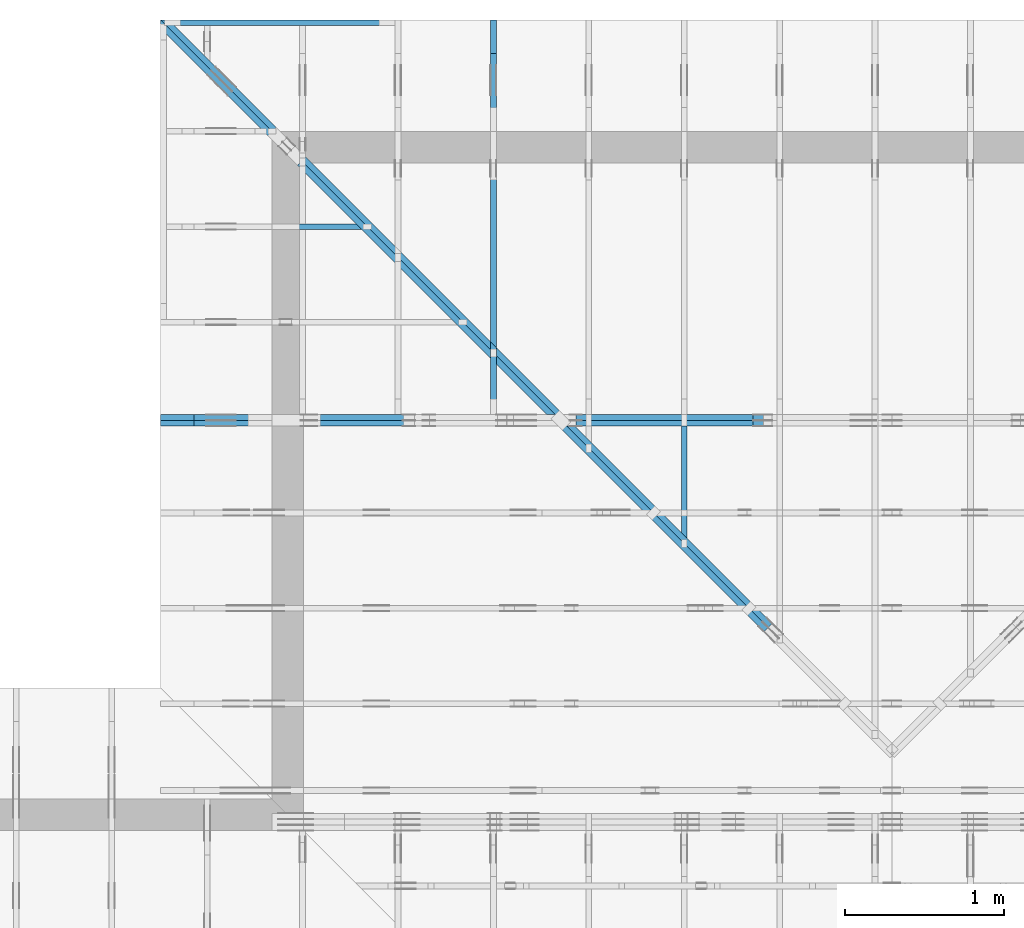
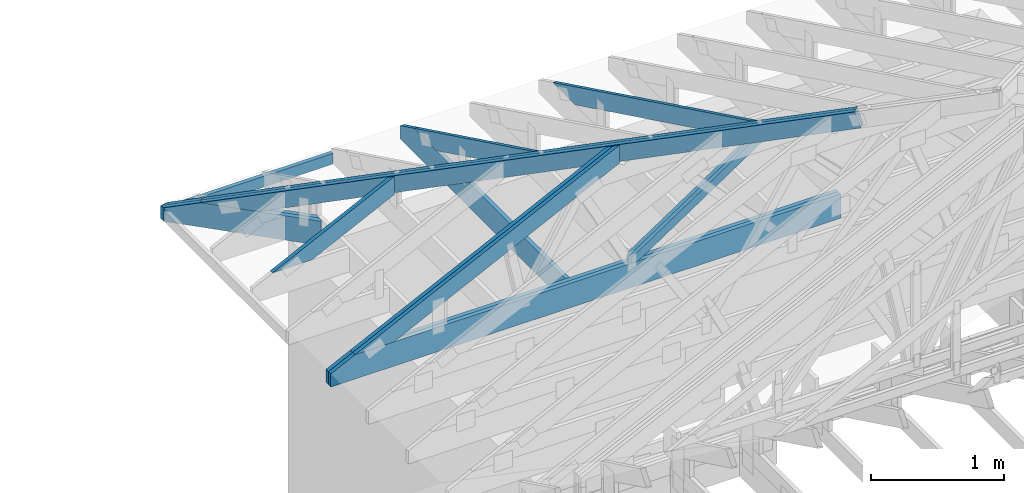
# One storey, part 26 of 159: 15 members, 6 elements without a shape of their own.
"""IFC2X3 building model written with IfcOpenShell, lengths in millimetres."""

from ifc_helpers import new_model, si_unit, frame, origin, origin_with_axes, origin_2d, place, context, project, spatial, faceted_brep, element, aggregate, save


model = new_model("IFC2X3")

# Units and contexts
model_context = context("Model", 3, precision=1e-05, world=origin())
plan_context = context("Plan", 2, precision=1e-05, world=origin_2d())
ifc_project = project(units=[si_unit("LENGTHUNIT", "METRE", prefix="MILLI"), si_unit("AREAUNIT", "SQUARE_METRE"), si_unit("VOLUMEUNIT", "CUBIC_METRE"), si_unit("SOLIDANGLEUNIT", "STERADIAN"), si_unit("PLANEANGLEUNIT", "RADIAN"), si_unit("MASSUNIT", "GRAM"), si_unit("TIMEUNIT", "SECOND"), si_unit("THERMODYNAMICTEMPERATUREUNIT", "DEGREE_CELSIUS"), si_unit("LUMINOUSINTENSITYUNIT", "LUMEN")], contexts=[model_context, plan_context])

# Site, building, storey
site_placement = place(None, origin_with_axes())
site = spatial("IfcSite", under=ifc_project, at=site_placement, CompositionType="ELEMENT")
building_placement = place(site_placement, origin_with_axes())
building = spatial("IfcBuilding", under=site, at=building_placement, Name="Plan 1", CompositionType="ELEMENT")
storey_placement = place(building_placement, origin_with_axes())
storey = spatial("IfcBuildingStorey", under=building, at=storey_placement, Name="Etasje 1", CompositionType="ELEMENT", Elevation=0.0)

# Assembly, members
assembly_1_placement = place(storey_placement, frame((19200.01266310149, 11417.999978540158, 0.0), z_axis=(1.2246063538223773e-16, 1.0, 6.123031769111886e-17), x_axis=(-1.0, 1.2246063538223773e-16, 0.0)))
assembly_1 = element("IfcElementAssembly", 1, at=assembly_1_placement, inside=storey, Name="V9 (1)", AssemblyPlace="FACTORY", PredefinedType="TRUSS")
member_1_placement = place(assembly_1_placement, frame((6668.032755825764, 1190.2578492598336, -36.00000303026507), z_axis=(0.0, 0.0, 1.0), x_axis=(0.8987940462991668, -0.4383711467890778, 0.0)))
member_1 = element("IfcMember", 2, at=member_1_placement, Name="V9-O46.1", context=model_context, shape_type="Brep", body=[
    faceted_brep([(112.23809529651042, 1.8631790243972546e-06, 36.000003247877885), (40.05367134545978, 147.99999667990065, 36.000000217612396), (1.4029538029092237e-06, 147.9999963587215, -1.4210854715202004e-14), (72.18442535400389, 1.5420000654131627e-06, 3.030265069980942e-06), (2.246607436973136e-06, 148.00000154128065, 3.030265069980942e-06), (40.053671222437515, 148.00000154128065, 36.00000303026507), (2509.9265159184815, 148.0000015412805, 36.00000303026507), (2509.9265159184815, 148.0000015412805, 3.030265069980942e-06), (2509.926474838091, 148.0000015409396, 36.00000303026507), (40.05367210371605, 148.0000015409396, 36.00000303026507), (112.23809745772087, 1.5412751963594928e-06, 36.00000303026507), (2206.481650619341, 1.5412751963594928e-06, 36.00000303026507), (2206.4815034142393, 1.5419923823685016e-06, 3.030265069980942e-06), (2206.4815034142393, 1.541992384572793e-06, 36.00000303026507), (112.23809521111343, 1.5419927692663607e-06, 36.00000303026507), (72.18442623528426, 1.5419927744195658e-06, 3.030265069980942e-06), (2509.926525858911, 148.0000015409397, 3.030265069980942e-06), (2509.926525858911, 148.0000015409397, 36.00000303026507), (2206.48155414578, 1.1368683772161603e-13, 36.00000303026507), (2206.48155414578, 1.1368683772161603e-13, 3.030265069980942e-06), (0.0, 148.00000154200006, 3.030265069980942e-06), (2509.926612854004, 148.00000154200006, 3.0302653773481497e-06), (2206.481544494627, 1.5416076166729908e-06, 3.030265340188074e-06), (72.1844253540039, 1.5416076166729908e-06, 3.0302650788206925e-06)], [[[0, 1, 2, 3]], [[4, 5, 6, 7]], [[8, 9, 10, 11]], [[12, 13, 14, 15]], [[16, 17, 18, 19]], [[20, 21, 22, 23]]]),
])
member_2_placement = place(assembly_1_placement, frame((6632.032729856588, 1207.8162351142178, -72.00000021755177), z_axis=(0.0, 0.0, 1.0), x_axis=(0.8987940462991668, -0.4383711467890778, 0.0)))
member_2 = element("IfcMember", 3, at=member_2_placement, Name="V9-O46.1", context=model_context, shape_type="Brep", body=[
    faceted_brep([(112.23812494821867, 6.724607814589945e-06, 36.000003247706054), (40.05370099707035, 148.00000154128068, 36.000000217551765), (3.1054509260997065e-05, 148.00000122007535, -2.1316282072803006e-14), (72.18445500565865, 6.403402132093561e-06, 3.0301550850708736e-06), (2246.535243245091, 1.541999650968606e-06, 2.1755177215254662e-07), (2246.535243245091, 1.5419996531728973e-06, 36.00000021755177), (112.2381241044659, 1.5420000452239693e-06, 36.00000021755177), (72.18445512863582, 1.5420000503771744e-06, 2.1755177215254662e-07), (3.113996172032785e-05, 148.0000015412861, 2.1755177215254662e-07), (40.05370011579089, 148.0000015412861, 36.00000021755177), (2549.980255749336, 148.00000154128594, 36.00000021755177), (2549.980255749336, 148.00000154128597, 2.1755177215254662e-07), (2549.980224609373, 148.00000154093993, 2.1755177215254662e-07), (2549.980224609373, 148.00000154093993, 36.00000021755177), (2246.535252896242, 1.1368683772161603e-13, 36.00000021755177), (2246.535252896242, 1.1368683772161603e-13, 2.1755177215254662e-07), (2549.9802146689435, 148.0000015409396, 36.00000021755177), (40.05370099707034, 148.0000015409396, 36.00000021755177), (112.23812635107424, 1.5412811080750544e-06, 36.00000021755177), (2246.5351463095685, 1.5412811080750544e-06, 36.00000021755177), (0.0, 148.0000015412861, 2.1755177215254662e-07), (2549.980224609373, 148.0000015412861, 2.1755208442474512e-07), (2246.5352478027326, 1.5409395928145386e-06, 2.1755204726468048e-07), (72.18457031249818, 1.5409395928145386e-06, 2.1755178099231496e-07)], [[[0, 1, 2, 3]], [[4, 5, 6, 7]], [[8, 9, 10, 11]], [[12, 13, 14, 15]], [[16, 17, 18, 19]], [[20, 21, 22, 23]]]),
])
member_3_placement = place(assembly_1_placement, frame((9200.0, 222.99999999999997, -36.0), z_axis=(0.0, 0.0, 1.0), x_axis=(-1.0, 1.2246063538223773e-16, 0.0)))
member_3 = element("IfcMember", 4, at=member_3_placement, Name="V9-U7", context=model_context, shape_type="Brep", body=[
    faceted_brep([(4420.0, 223.00000000000017, 36.0), (0.0, 223.00000000000017, 36.0), (0.0, 102.99998474121092, 36.0), (211.181640625, 0.0, 36.0), (4420.0, 0.0, 36.0), (0.0, 223.00000000000017, 0.0), (4420.0, 223.00000000000017, 5.412760083894907e-13), (4420.0, 0.0, 5.412760083894907e-13), (211.181640625, 0.0, 2.5861437892000887e-14), (0.0, 102.99998474121092, 0.0), (3.221100815960074e-05, 102.99998428962134, -7.723249910891245e-31), (3.2211008161805034e-05, 102.99998428962134, 36.0), (3.221100817650031e-05, 222.99999999999997, 36.0), (3.221100817429602e-05, 222.99999999999997, -1.6721217180559947e-30), (211.18129568360746, -4.263256414560601e-14, 2.951475286859823e-30), (211.18129568360746, -4.263256414560601e-14, 36.0), (3.22110081469873e-05, 102.99998428962135, 36.0), (3.22110081469873e-05, 102.99998428962134, -1.3913593467013756e-31), (4420.0, -8.204705228709351e-13, 6.06792925580756e-29), (4420.0, -8.182662314340548e-13, 36.0), (211.18129568360746, -4.5144312325206896e-14, 36.0), (211.18129568360746, -4.7348603762087175e-14, 2.8991700505835032e-30), (4420.0, 223.00000000000017, 0.0), (4420.0, 223.00000000000017, 36.0), (4420.0, 1.7053025658242404e-13, 36.0), (4420.0, 1.7053025658242404e-13, 0.0), (3.22110081469873e-05, 222.99999999999997, 0.0), (3.22110081469873e-05, 222.99999999999997, 36.0), (4420.0, 222.9999999999997, 36.0), (4420.0, 222.9999999999997, -2.997671439839845e-29)], [[[0, 1, 2, 3, 4]], [[5, 6, 7, 8, 9]], [[10, 11, 12, 13]], [[14, 15, 16, 17]], [[18, 19, 20, 21]], [[22, 23, 24, 25]], [[26, 27, 28, 29]]]),
])
member_4_placement = place(assembly_1_placement, frame((9200.0, 222.99999999999997, -72.0), z_axis=(0.0, 0.0, 1.0), x_axis=(-1.0, 1.2246063538223773e-16, 0.0)))
member_4 = element("IfcMember", 5, at=member_4_placement, Name="V9-U7", context=model_context, shape_type="Brep", body=[
    faceted_brep([(4420.0, 223.00000000000017, 36.0), (0.0, 223.00000000000017, 36.0), (0.0, 102.99998474121092, 36.0), (211.181640625, 0.0, 36.0), (4420.0, 0.0, 36.0), (0.0, 223.00000000000017, 0.0), (4420.0, 223.00000000000017, 5.412760083894907e-13), (4420.0, 0.0, 5.412760083894907e-13), (211.181640625, 0.0, 2.5861437892000887e-14), (0.0, 102.99998474121092, 0.0), (3.221100815960074e-05, 102.99998428962134, -7.723249910891245e-31), (3.2211008161805034e-05, 102.99998428962134, 36.0), (3.221100817650031e-05, 222.99999999999997, 36.0), (3.221100817429602e-05, 222.99999999999997, -1.6721217180559947e-30), (211.18129568360746, -4.263256414560601e-14, 2.951475286859823e-30), (211.18129568360746, -4.263256414560601e-14, 36.0), (3.22110081469873e-05, 102.99998428962135, 36.0), (3.22110081469873e-05, 102.99998428962134, -1.3913593467013756e-31), (4420.0, -8.204705228709351e-13, 6.06792925580756e-29), (4420.0, -8.182662314340548e-13, 36.0), (211.18129568360746, -4.5144312325206896e-14, 36.0), (211.18129568360746, -4.7348603762087175e-14, 2.8991700505835032e-30), (4420.0, 223.00000000000017, 0.0), (4420.0, 223.00000000000017, 36.0), (4420.0, 1.7053025658242404e-13, 36.0), (4420.0, 1.7053025658242404e-13, 0.0), (3.22110081469873e-05, 222.99999999999997, 0.0), (3.22110081469873e-05, 222.99999999999997, 36.0), (4420.0, 222.9999999999997, 36.0), (4420.0, 222.9999999999997, -2.997671439839845e-29)], [[[0, 1, 2, 3, 4]], [[5, 6, 7, 8, 9]], [[10, 11, 12, 13]], [[14, 15, 16, 17]], [[18, 19, 20, 21]], [[22, 23, 24, 25]], [[26, 27, 28, 29]]]),
])
member_5_placement = place(assembly_1_placement, frame((5386.919696219395, 987.5053658497195, -36.0), z_axis=(0.0, 0.0, 1.0), x_axis=(0.832376439520055, -0.5542106665627397, 0.0)))
member_5 = element("IfcMember", 6, at=member_5_placement, Name="V9-D34", context=model_context, shape_type="Brep", body=[
    faceted_brep([(1393.8874955119636, 73.0000459270309, 36.0), (54.81984691468824, 73.0000459270309, 36.0), (5.4843172620167024e-05, 36.50001136914352, 36.0), (29.67221533132306, 2.6872354737861315e-05, 36.0), (1379.4490768791748, 2.6872354737861315e-05, 36.0), (1434.2688689506913, 36.50001136914352, 36.0), (54.81984691468824, 73.0000459270309, 6.7132732847297265e-15), (1393.8874955119636, 73.0000459270309, 1.706963483517511e-13), (1434.2688689506913, 36.50001136914352, 1.7564147700066512e-13), (1379.4490768791748, 2.6872354737861315e-05, 1.6892821043206502e-13), (29.67221533132306, 2.6872354737861315e-05, 3.633678342672397e-15), (5.4843172620167024e-05, 36.50001136914352, 6.716129765443397e-21), (3.552713678800501e-15, 36.5, -3.944304526105059e-31), (3.552713678800501e-15, 36.49999999999999, 36.0), (54.819839955287534, 73.00000000000045, 36.0), (54.819839955287534, 73.00000000000045, 0.0), (29.67219060517072, -1.7763568394002505e-15, 1.972152263052529e-31), (29.672190605170723, 0.0, 36.0), (7.105427357601002e-15, 36.500000000000014, 36.0), (7.105427357601002e-15, 36.500000000000014, -9.860761315262648e-31), (1379.4490289969444, 9.418143718714962e-13, 2.5865381096165426e-29), (1379.4490289969444, 9.440186633083765e-13, 36.0), (29.672190605170726, -6.882202081733401e-15, 36.0), (29.672190605170726, -9.08649351861368e-15, 5.56368884843008e-31), (1434.2688689521651, 36.50000000005923, -6.941975965944904e-29), (1434.2688689521651, 36.50000000005923, 36.0), (1379.4490289969438, 2.1600499167107046e-12, 36.0), (1379.4490289969438, 2.1600499167107046e-12, -6.941975965944904e-29), (1393.887442995444, 73.00000000000227, 0.0), (1393.887442995444, 73.00000000000227, 36.0), (1434.2688689521658, 36.500000000058094, 36.0), (1434.2688689521658, 36.500000000058094, 0.0), (54.819839955287534, 73.00000000000045, 0.0), (54.819839955287534, 73.00000000000045, 36.0), (1393.887442995444, 73.00000000000216, 36.0), (1393.887442995444, 73.00000000000216, -6.310887241768095e-30)], [[[0, 1, 2, 3, 4, 5]], [[6, 7, 8, 9, 10, 11]], [[12, 13, 14, 15]], [[16, 17, 18, 19]], [[20, 21, 22, 23]], [[24, 25, 26, 27]], [[28, 29, 30, 31]], [[32, 33, 34, 35]]]),
])
member_6_placement = place(assembly_1_placement, frame((5386.919696219395, 987.5053658497195, -72.0), z_axis=(0.0, 0.0, 1.0), x_axis=(0.832376439520055, -0.5542106665627397, 0.0)))
member_6 = element("IfcMember", 7, at=member_6_placement, Name="V9-D34", context=model_context, shape_type="Brep", body=[
    faceted_brep([(1393.8874955119636, 73.0000459270309, 36.0), (54.81984691468824, 73.0000459270309, 36.0), (5.4843172620167024e-05, 36.50001136914352, 36.0), (29.67221533132306, 2.6872354737861315e-05, 36.0), (1379.4490768791748, 2.6872354737861315e-05, 36.0), (1434.2688689506913, 36.50001136914352, 36.0), (54.81984691468824, 73.0000459270309, 6.7132732847297265e-15), (1393.8874955119636, 73.0000459270309, 1.706963483517511e-13), (1434.2688689506913, 36.50001136914352, 1.7564147700066512e-13), (1379.4490768791748, 2.6872354737861315e-05, 1.6892821043206502e-13), (29.67221533132306, 2.6872354737861315e-05, 3.633678342672397e-15), (5.4843172620167024e-05, 36.50001136914352, 6.716129765443397e-21), (3.552713678800501e-15, 36.5, -3.944304526105059e-31), (3.552713678800501e-15, 36.49999999999999, 36.0), (54.819839955287534, 73.00000000000045, 36.0), (54.819839955287534, 73.00000000000045, 0.0), (29.67219060517072, -1.7763568394002505e-15, 1.972152263052529e-31), (29.672190605170723, 0.0, 36.0), (7.105427357601002e-15, 36.500000000000014, 36.0), (7.105427357601002e-15, 36.500000000000014, -9.860761315262648e-31), (1379.4490289969444, 9.418143718714962e-13, 2.5865381096165426e-29), (1379.4490289969444, 9.440186633083765e-13, 36.0), (29.672190605170726, -6.882202081733401e-15, 36.0), (29.672190605170726, -9.08649351861368e-15, 5.56368884843008e-31), (1434.2688689521651, 36.50000000005923, -6.941975965944904e-29), (1434.2688689521651, 36.50000000005923, 36.0), (1379.4490289969438, 2.1600499167107046e-12, 36.0), (1379.4490289969438, 2.1600499167107046e-12, -6.941975965944904e-29), (1393.887442995444, 73.00000000000227, 0.0), (1393.887442995444, 73.00000000000227, 36.0), (1434.2688689521658, 36.500000000058094, 36.0), (1434.2688689521658, 36.500000000058094, 0.0), (54.819839955287534, 73.00000000000045, 0.0), (54.819839955287534, 73.00000000000045, 36.0), (1393.887442995444, 73.00000000000216, 36.0), (1393.887442995444, 73.00000000000216, -6.310887241768095e-30)], [[[0, 1, 2, 3, 4, 5]], [[6, 7, 8, 9, 10, 11]], [[12, 13, 14, 15]], [[16, 17, 18, 19]], [[20, 21, 22, 23]], [[24, 25, 26, 27]], [[28, 29, 30, 31]], [[32, 33, 34, 35]]]),
])
aggregate(assembly_1, [member_1, member_2, member_3, member_4, member_5, member_6])

assembly_2_placement = place(storey_placement, frame((9974.55681897877, 13874.544134417441, 2.204291436880279e-15), z_axis=(-0.7071067811865477, -0.7071067811865474, 6.123031769111886e-17), x_axis=(0.7071067811865474, -0.7071067811865477, 0.0)))
assembly_2 = element("IfcElementAssembly", 8, at=assembly_2_placement, inside=storey, Name="GR2 (61)", AssemblyPlace="FACTORY", PredefinedType="TRUSS")
member_7_placement = place(assembly_2_placement, frame((364.9085270170932, 83.08695328933156, -36.0), z_axis=(0.0, 0.0, 1.0), x_axis=(0.9453579955214151, 0.3260341397825261, 0.0)))
member_7 = element("IfcMember", 9, at=member_7_placement, Name="GR2-O2", context=model_context, shape_type="Brep", body=[
    faceted_brep([(5380.0001787038955, 148.00005689174122, 36.0), (3.847493246667e-06, 148.00005689174122, 36.0), (429.13598774270645, 6.780209275802918e-05, 36.0), (5380.000028973355, 6.780209275802918e-05, 36.0), (3.847493246667e-06, 148.00005689174122, 4.711664676157095e-22), (5380.0001787038955, 148.00005689174122, 6.588382402406316e-13), (5380.000028973355, 6.780209275802918e-05, 6.588382219045345e-13), (429.13598774270645, 6.780209275802918e-05, 5.255226572435601e-14), (429.1359899649197, 6.703569724209046e-05, 9.466330862652142e-30), (429.1359899649197, 6.703569724209046e-05, 36.0), (-7.105427357601002e-15, 148.0000670365081, 36.0), (-7.105427357601002e-15, 148.0000670365081, -1.5777218104420243e-30), (5379.999999999999, 6.703622873176832e-05, -1.2378644861661829e-28), (5379.999999999999, 6.703622873397261e-05, 36.0), (429.13598996491964, 6.703569757608226e-05, 36.0), (429.13598996491964, 6.703569757387797e-05, -9.873832812443791e-30), (5379.999999999999, 148.0000670362274, -5.048709793414476e-29), (5379.999999999999, 148.0000670362274, 36.0), (5379.999999999999, 6.703622671011544e-05, 36.0), (5379.999999999999, 6.703622671011544e-05, 0.0), (0.0, 148.00006703650809, 0.0), (0.0, 148.00006703650809, 36.0), (5380.0, 148.00006703622822, 36.0), (5380.0, 148.00006703622822, 5.206481974458678e-29)], [[[0, 1, 2, 3]], [[4, 5, 6, 7]], [[8, 9, 10, 11]], [[12, 13, 14, 15]], [[16, 17, 18, 19]], [[20, 21, 22, 23]]]),
])
member_8_placement = place(assembly_2_placement, frame((364.9085270170932, 83.08695328933156, -72.0), z_axis=(0.0, 0.0, 1.0), x_axis=(0.9453579955214151, 0.3260341397825261, 0.0)))
member_8 = element("IfcMember", 10, at=member_8_placement, Name="GR2-O2", context=model_context, shape_type="Brep", body=[
    faceted_brep([(5380.0001787038955, 148.00005689174122, 36.0), (3.847493246667e-06, 148.00005689174122, 36.0), (429.13598774270645, 6.780209275802918e-05, 36.0), (5380.000028973355, 6.780209275802918e-05, 36.0), (3.847493246667e-06, 148.00005689174122, 4.711664676157095e-22), (5380.0001787038955, 148.00005689174122, 6.588382402406316e-13), (5380.000028973355, 6.780209275802918e-05, 6.588382219045345e-13), (429.13598774270645, 6.780209275802918e-05, 5.255226572435601e-14), (429.1359899649197, 6.703569724209046e-05, 9.466330862652142e-30), (429.1359899649197, 6.703569724209046e-05, 36.0), (-7.105427357601002e-15, 148.0000670365081, 36.0), (-7.105427357601002e-15, 148.0000670365081, -1.5777218104420243e-30), (5379.999999999999, 6.703622873176832e-05, -1.2378644861661829e-28), (5379.999999999999, 6.703622873397261e-05, 36.0), (429.13598996491964, 6.703569757608226e-05, 36.0), (429.13598996491964, 6.703569757387797e-05, -9.873832812443791e-30), (5379.999999999999, 148.0000670362274, -5.048709793414476e-29), (5379.999999999999, 148.0000670362274, 36.0), (5379.999999999999, 6.703622671011544e-05, 36.0), (5379.999999999999, 6.703622671011544e-05, 0.0), (0.0, 148.00006703650809, 0.0), (0.0, 148.00006703650809, 36.0), (5380.0, 148.00006703622822, 36.0), (5380.0, 148.00006703622822, 5.206481974458678e-29)], [[[0, 1, 2, 3]], [[4, 5, 6, 7]], [[8, 9, 10, 11]], [[12, 13, 14, 15]], [[16, 17, 18, 19]], [[20, 21, 22, 23]]]),
])
member_9_placement = place(assembly_2_placement, frame((1255.4504411287128, 223.00000401659273, -36.00000106970323), z_axis=(0.0, 0.0, 1.0), x_axis=(-1.0, 1.010639055082363e-15, 0.0)))
member_9 = element("IfcMember", 11, at=member_9_placement, Name="GR2-U20.1", context=model_context, shape_type="Brep", body=[
    faceted_brep([(18.000000536496145, 4.016592739757909e-06, 5.332061210339134e-07), (1.5936603148247741e-09, 4.016592725974989e-06, 18.000001068063476), (1.5934613628587613e-09, 223.00000401659273, 18.000001068063504), (18.000000536496177, 223.00000401659273, 5.332059220819474e-07), (938.7949829117499, 4.0165942211617315e-06, 1.0680634829896007e-06), (938.7949829117499, 4.016594223366023e-06, 36.00000106806348), (1.5936620911816133e-09, 4.016592728179279e-06, 36.00000106806348), (1.5936620911816133e-09, 4.0165927270771336e-06, 18.00000106806348), (18.000000001593662, 4.016592754642974e-06, 1.0680634829896007e-06), (18.0, 223.00000401658383, 1.0697032330869152e-06), (1255.4504394531252, 223.00000401658383, 1.0697033846258823e-06), (1255.4504394531252, 109.20782109422055, 1.0697033846258823e-06), (938.7949829101565, 4.016128031025801e-06, 1.069703345848054e-06), (18.000000000000227, 4.016128031025801e-06, 1.0697032330869152e-06), (1255.4504421983197, 223.00000634935563, -9.549694368615746e-11), (1219.4504411286657, 223.00000634935563, 36.00000106966206), (1219.4504411286657, 96.79218164232438, 36.000001069661835), (1255.4504341061738, 109.20782342702334, 8.09205039331573e-06), (-6.748473649247598e-32, 223.00000401659295, 18.00000106970323), (-1.3496946897447216e-31, 223.00000401659295, 36.00000106970323), (1219.450439453125, 223.00000401659287, 36.00000106970323), (1255.450439453125, 223.00000401659287, 1.0697032308826238e-06), (18.0, 223.00000401659295, 1.0697032308826238e-06), (1.5936631933293672e-09, 8.218622042477364e-06, 18.000000810672187), (1.5936642954750087e-09, 8.218622042477364e-06, 35.99999955235686), (1.5934935404123043e-09, 223.00000411556908, 36.000000481123806), (1.5934924382666219e-09, 223.00000411556908, 18.00000106806348), (1255.4504335264874, 109.20782376856789, 8.671830372009026e-06), (1219.4504420125681, 96.79218194714997, 36.000001042435834), (938.7950007267278, 8.179838573596498e-06, 36.000001042435805), (938.7950007267278, 8.179838573596498e-06, 1.069703372991171e-06), (1219.450441128707, 223.00000634935563, 36.00000106970323), (1.6755823253333801e-06, 223.00000634935563, 36.00000106970323), (1.6755823253333801e-06, 6.349355629708953e-06, 36.00000106970323), (938.7949845857385, 6.349355629708953e-06, 36.00000106970323), (1219.4504411287073, 96.79218164232438, 36.00000106970323)], [[[0, 1, 2, 3]], [[4, 5, 6, 7, 8]], [[9, 10, 11, 12, 13]], [[14, 15, 16, 17]], [[18, 19, 20, 21, 22]], [[23, 24, 25, 26]], [[27, 28, 29, 30]], [[31, 32, 33, 34, 35]]]),
])
member_10_placement = place(assembly_2_placement, frame((1237.4504411287128, 223.0000036038742, -72.00000106971108), z_axis=(0.0, 0.0, 1.0), x_axis=(-1.0, 1.010639055082363e-15, 0.0)))
member_10 = element("IfcMember", 12, at=member_10_placement, Name="GR2-U20.1", context=model_context, shape_type="Brep", body=[
    faceted_brep([(36.00000106980924, 3.60387438383858e-06, -5.3290705182007514e-14), (0.0, 3.603874404234375e-06, 36.00000106971096), (1.0658141036401503e-14, 223.0000036038744, 36.000001069711075), (36.0000010698093, 223.0000036038744, 7.105427357601002e-15), (920.7949829101565, 3.60386511172394e-06, 1.0697110752744265e-06), (920.7949829101565, 3.6038651139282315e-06, 36.000001069711075), (2.2737367544323206e-13, 3.6038652830699394e-06, 36.000001069711075), (36.00000000000023, 3.6038652742527736e-06, 1.0697110752744265e-06), (36.00000000009277, 223.00000360384746, 1.0697110796830094e-06), (1201.4504394532178, 223.00000360384746, 1.0697112224048108e-06), (1201.4504394532178, 96.79217889681621, 1.0697112224048108e-06), (920.794982910249, 3.6034094819115126e-06, 1.0697111880355653e-06), (36.00000000009277, 3.6034094819115126e-06, 1.0697110796830094e-06), (1201.4504405489683, 223.00000627821188, 4.898703309663688e-07), (1237.4504411287144, 223.00000627821188, 36.0000010697089), (1237.4504335264874, 109.2078233558486, 35.999993467482), (1201.4504405489683, 96.79218157118068, 4.898703309663688e-07), (9.276845958083868e-11, 223.00000360387486, 36.000001069711075), (1237.4504394532178, 223.00000360387477, 36.000001069711075), (1201.4504394532178, 223.00000360387477, 1.0697110752744265e-06), (36.00000000009277, 223.00000360387486, 1.0697110752744265e-06), (1237.4504326427284, 109.20782305105905, 35.999993440316544), (920.794978205442, 0.0, 36.00000106971107), (920.794978205442, 0.0, 1.0697110752744265e-06), (1201.4504411288094, 96.79218122964102, 1.0697110752744265e-06), (1237.450439453125, 223.00000360389, 36.000001069711075), (0.0, 223.00000360389, 36.000001069711075), (2.2737367544323206e-13, 3.603874404234375e-06, 36.000001069711075), (920.7949829101562, 3.603874404234375e-06, 36.000001069711075), (1237.450439453125, 109.20782068151114, 36.000001069711075)], [[[0, 1, 2, 3]], [[4, 5, 6, 7]], [[8, 9, 10, 11, 12]], [[13, 14, 15, 16]], [[17, 18, 19, 20]], [[21, 22, 23, 24]], [[25, 26, 27, 28, 29]]]),
])
aggregate(assembly_2, [member_7, member_8, member_9, member_10])

assembly_3_placement = place(storey_placement, frame((12075.022261404758, 13899.999978540158, 1.1021457184401395e-15), z_axis=(-1.0, 1.836909530733566e-16, 6.123031769111886e-17), x_axis=(-1.836909530733566e-16, -1.0, 0.0)))
assembly_3 = element("IfcElementAssembly", 13, at=assembly_3_placement, inside=storey, Name="S32 (63)", AssemblyPlace="FACTORY", PredefinedType="TRUSS")
member_11_placement = place(assembly_3_placement, frame((276.0601884466148, 89.97846276331934, -36.00000021758541), z_axis=(0.0, 0.0, 1.0), x_axis=(0.8987940462991671, 0.4383711467890776, 0.0)))
member_11 = element("IfcMember", 14, at=member_11_placement, Name="S32-O55", context=model_context, shape_type="Brep", body=[
    faceted_brep([(2057.430473760923, 148.0000008308213, 2.253329398627102e-06), (2017.3768067635879, 147.99999513789095, 35.999997187375584), (1945.1923828125005, 3.211876560271776e-07, 36.000000217585125), (1985.2460527550306, 0.0, -2.2737367544323206e-13), (9.693633870710983e-05, 148.00000032214302, 2.1758540214023014e-07), (9.693633870710983e-05, 148.00000032214302, 36.0000002175854), (2017.3768059207137, 148.0000003221429, 36.0000002175854), (2057.4304748965437, 148.0000003221429, 2.1758540214023014e-07), (303.4450098342561, 3.206678371725502e-07, 2.1758540214023014e-07), (303.4450098342561, 3.206678371725502e-07, 36.0000002175854), (3.812112482393104e-05, 148.0000018616081, 36.0000002175854), (3.812112482393104e-05, 148.0000018616081, 2.1758540214023014e-07), (1985.2460526696127, 3.2119998047528456e-07, 2.1758540214023014e-07), (1945.1923836937822, 3.2119987013298597e-07, 36.0000002175854), (303.44502727898737, 3.2120017170712256e-07, 36.0000002175854), (303.44502727898737, 3.212002894069178e-07, 2.1758540214023014e-07), (2017.3768081665044, 148.0000003211877, 36.0000002175854), (0.0, 148.0000003211877, 36.0000002175854), (303.4450683593751, 3.2066796507024264e-07, 36.0000002175854), (1945.1923828125005, 3.2066796507024264e-07, 36.0000002175854), (5.5855949653960124e-05, 148.0000003216327, 2.1758540214023697e-07), (2057.4304757778245, 148.0000003216327, 2.1758565409447346e-07), (1985.2460504238206, 3.221530278096907e-07, 2.1758564525472288e-07), (303.44500214501227, 3.221530278096907e-07, 2.175854393002979e-07)], [[[0, 1, 2, 3]], [[4, 5, 6, 7]], [[8, 9, 10, 11]], [[12, 13, 14, 15]], [[16, 17, 18, 19]], [[20, 21, 22, 23]]]),
])
member_12_placement = place(assembly_3_placement, frame((2482.0, 223.00000000093104, -36.0), z_axis=(0.0, 0.0, 1.0), x_axis=(-1.0, 1.2246063538223773e-16, 0.0)))
member_12 = element("IfcMember", 15, at=member_12_placement, Name="S32-U12", context=model_context, shape_type="Brep", body=[
    faceted_brep([(2482.0, 223.00000000093135, 36.0), (0.0, 223.00000000093135, 36.0), (0.0, 9.310383575211745e-10, 36.0), (2270.8187103271484, 9.310383575211745e-10, 36.0), (2482.000000000002, 103.00000000093135, 36.0), (0.0, 223.00000000093135, 0.0), (2482.0, 223.00000000093135, 3.0394729701871404e-13), (2482.000000000002, 103.00000000093135, 3.0394729701871424e-13), (2270.8187103271484, 9.310383575211745e-10, 2.7808590210453623e-13), (0.0, 9.310383575211745e-10, 0.0), (1.1401554882727804e-25, 9.310383575211745e-10, -6.981208276421509e-42), (2.2042914369942947e-15, 9.310383575211745e-10, 36.0), (2.9513013127233304e-14, 223.00000000093104, 36.0), (2.730872169035303e-14, 223.00000000093104, -1.6721217048386645e-30), (2270.8187043163925, 8.339391172955722e-13, -5.106235708706442e-29), (2270.8187043163925, 8.361434087324525e-13, 36.0), (9.029525915557911e-28, 9.310405618126114e-10, 36.0), (0.0, 9.310383575211745e-10, 0.0), (2482.000000000001, 103.00000000074351, -9.396085556655556e-29), (2482.000000000001, 103.00000000074351, 36.0), (2270.818704316392, 1.2505552149377763e-12, 36.0), (2270.818704316392, 1.2505552149377763e-12, -8.206310969932178e-29), (2482.000000000003, 223.00000000093135, 2.0194839173657902e-28), (2482.000000000003, 223.00000000093135, 36.0), (2482.000000000003, 103.00000000074218, 36.0), (2482.000000000003, 103.00000000074218, 1.0097419586828951e-28), (0.0, 223.00000000093104, 0.0), (0.0, 223.00000000093104, 36.0), (2482.0, 223.00000000093144, 36.0), (2482.0, 223.00000000093144, 4.733165431326071e-30)], [[[0, 1, 2, 3, 4]], [[5, 6, 7, 8, 9]], [[10, 11, 12, 13]], [[14, 15, 16, 17]], [[18, 19, 20, 21]], [[22, 23, 24, 25]], [[26, 27, 28, 29]]]),
])
aggregate(assembly_3, [member_11, member_12])

# Assembly, member
assembly_4_placement = place(storey_placement, frame((13275.022261404756, 13899.999978540158, 1.1021457184401395e-15), z_axis=(-1.0, 1.836909530733566e-16, 6.123031769111886e-17), x_axis=(-1.836909530733566e-16, -1.0, 0.0)))
assembly_4 = element("IfcElementAssembly", 16, at=assembly_4_placement, inside=storey, Name="S34 (71)", AssemblyPlace="FACTORY", PredefinedType="TRUSS")
member_13_placement = place(assembly_4_placement, frame((276.0602227096395, 89.97847947456265, -36.00000021758839), z_axis=(0.0, 0.0, 1.0), x_axis=(0.8987940462991669, 0.43837114678907757, 0.0)))
member_13 = element("IfcMember", 17, at=member_13_placement, Name="S34-O34", context=model_context, shape_type="Brep", body=[
    faceted_brep([(3392.230542642649, 148.00000083082796, 2.253328602819238e-06), (3352.1768756453157, 147.99999513789237, 35.99999718737763), (3279.992451694242, 3.2118293802341213e-07, 36.00000021758797), (3320.04612163677, 0.0, -4.547473508864641e-13), (0.00011698994558173581, 148.00000032211761, 2.175883935251477e-07), (0.00011698994558173581, 148.00000032211761, 36.00000021758839), (3352.1768748024456, 148.00000032211815, 36.00000021758839), (3392.2305437782757, 148.00000032211815, 2.175883935251477e-07), (303.4449717131266, 3.206231298236162e-07, 2.175883935251477e-07), (303.4449717131266, 3.206231298236162e-07, 36.00000021758839), (1.4210854715202004e-14, 148.0000018615731, 36.00000021758839), (1.4210854715202004e-14, 148.0000018615731, 2.175883935251477e-07), (3320.046121551353, 3.2119010158259146e-07, 2.175883935251477e-07), (3279.9924525755227, 3.21189879329812e-07, 36.00000021758839), (303.44504733260317, 3.2119042609464173e-07, 36.00000021758839), (303.44504733260317, 3.2119065570491784e-07, 2.175883935251477e-07), (3352.176877048246, 148.00000032118305, 36.00000021758839), (2.0053616708537447e-05, 148.00000032118305, 36.00000021758839), (303.4450884129918, 3.206233145647275e-07, 36.00000021758839), (3279.9924516942424, 3.206233145647275e-07, 36.00000021758839), (7.590956533931603e-05, 148.00000031995532, 2.1758839352515699e-07), (3392.230544659565, 148.00000031995532, 2.1758880893985555e-07), (3320.0461193055617, 3.221432507416466e-07, 2.1758880010010497e-07), (303.44490012831545, 3.221432507416466e-07, 2.1758843068520296e-07)], [[[0, 1, 2, 3]], [[4, 5, 6, 7]], [[8, 9, 10, 11]], [[12, 13, 14, 15]], [[16, 17, 18, 19]], [[20, 21, 22, 23]]]),
])
aggregate(assembly_4, [member_13])

assembly_5_placement = place(storey_placement, frame((10036.01266309785, 12581.999978540158, 1.1021457184401395e-15), z_axis=(0.0, -1.0, 6.123031769111886e-17), x_axis=(1.0, 0.0, 0.0)))
assembly_5 = element("IfcElementAssembly", 18, at=assembly_5_placement, inside=storey, Name="S27 (77)", AssemblyPlace="FACTORY", PredefinedType="TRUSS")
member_14_placement = place(assembly_5_placement, frame((240.06022165790753, 89.97847931608983, -36.00000021758058), z_axis=(0.0, 0.0, 1.0), x_axis=(0.8987940462991671, 0.43837114678907757, 0.0)))
member_14 = element("IfcMember", 19, at=member_14_placement, Name="S27-O68", context=model_context, shape_type="Brep", body=[
    faceted_brep([(1174.8042000624398, 147.9999948174072, 36.00000324777858), (1102.619776111355, 7.027836090855999e-10, 36.00000021758041), (1062.56610616882, 3.218890469725011e-07, -2.8421709430404007e-13), (1134.750530119905, 147.99999513859345, 3.0301980586955324e-06), (0.0, 147.99999999998158, 2.1758057755505433e-07), (0.0, 147.99999999998158, 36.00000021758058), (1174.8041992187502, 147.9999999999815, 36.00000021758058), (1134.75053024292, 147.99999999998153, 2.1758057755505433e-07), (4.108039922812168e-05, 148.00000000052438, 2.1758057755505936e-07), (1134.7505293616491, 148.00000000052438, 2.1758071651732516e-07), (1062.5661040076452, 2.842170943040401e-14, 2.1758070767757457e-07), (303.44498736946167, 2.842170943040401e-14, 2.175806147151203e-07), (303.4449727295611, 1.1922622888960177e-09, 2.1758057755505433e-07), (303.4449727295611, 1.1922622888960177e-09, 36.00000021758058), (1.0164298416270867e-06, 148.0000015421325, 36.00000021758058), (1.0164298416270867e-06, 148.0000015421325, 2.1758057755505433e-07), (1102.6197752300866, 7.273399868600623e-10, 36.00000021758058), (303.4449514691003, 7.274867880451111e-10, 36.00000021758058), (303.4449514691003, 7.274206349074559e-10, 2.1758057755505433e-07), (1062.5661062542565, 7.272811912190352e-10, 2.1758057755505433e-07), (1174.8042014653581, 148.000000000703, 36.00000021758058), (2.5134791940217838e-05, 148.000000000703, 36.00000021758058), (303.4449714238545, 1.1923759757337393e-09, 36.00000021758058), (1102.6197761113544, 1.1923759757337393e-09, 36.00000021758058)], [[[0, 1, 2, 3]], [[4, 5, 6, 7]], [[8, 9, 10, 11]], [[12, 13, 14, 15]], [[16, 17, 18, 19]], [[20, 21, 22, 23]]]),
])
aggregate(assembly_5, [member_14])

assembly_6_placement = place(storey_placement, frame((10025.468507224201, 13863.99997854016, 2.204291436880279e-15), z_axis=(0.0, -1.0, 6.123031769111886e-17), x_axis=(1.0, 0.0, 0.0)))
assembly_6 = element("IfcElementAssembly", 20, at=assembly_6_placement, inside=storey, Name="uu6 (1)", AssemblyPlace="FACTORY", PredefinedType="TRUSS")
member_15_placement = place(assembly_6_placement, frame((1449.5537541805588, 98.0, -36.0), z_axis=(0.0, 0.0, 1.0), x_axis=(-1.0, 5.665498452323003e-16, 0.0)))
member_15 = element("IfcMember", 21, at=member_15_placement, Name="uu6-U50", context=model_context, shape_type="Brep", body=[
    faceted_brep([(1449.5537541805588, 98.00000000000082, 36.0), (4.324305882619228e-05, 98.00000000000082, 36.0), (4.324305882619228e-05, 0.0, 36.0), (1449.5537541805588, 0.0, 36.0), (4.324305882619228e-05, 98.00000000000082, 5.29557245972699e-21), (1449.5537541805588, 98.00000000000082, 1.7751327375765928e-13), (1449.5537541805588, 0.0, 1.7751327375765928e-13), (4.324305882619228e-05, 0.0, 5.29557245972699e-21), (0.0, 0.0, 0.0), (2.204291436880279e-15, -2.6993892992798474e-31, 36.0), (1.4205433704339576e-14, 98.0, 36.0), (1.2001142267459297e-14, 98.0, -7.3483375369284735e-31), (1449.5537541805588, -2.662699106364889e-13, 6.677162985455893e-29), (1449.5537541805588, -2.640656191996086e-13, 36.0), (4.049083948919771e-31, 2.204291436880279e-15, 36.0), (0.0, 0.0, 0.0), (1449.5537541805588, 98.00000000000082, 0.0), (1449.5537541805588, 98.00000000000082, 36.0), (1449.5537541805588, 8.242295734817162e-13, 36.0), (1449.5537541805588, 8.242295734817162e-13, 0.0), (0.0, 98.0, 0.0), (0.0, 98.0, 36.0), (1449.5537541805588, 98.0000000000012, 36.0), (1449.5537541805588, 98.0000000000012, 2.2876966251409342e-29)], [[[0, 1, 2, 3]], [[4, 5, 6, 7]], [[8, 9, 10, 11]], [[12, 13, 14, 15]], [[16, 17, 18, 19]], [[20, 21, 22, 23]]]),
])
aggregate(assembly_6, [member_15])

save(model, "model.ifc")
